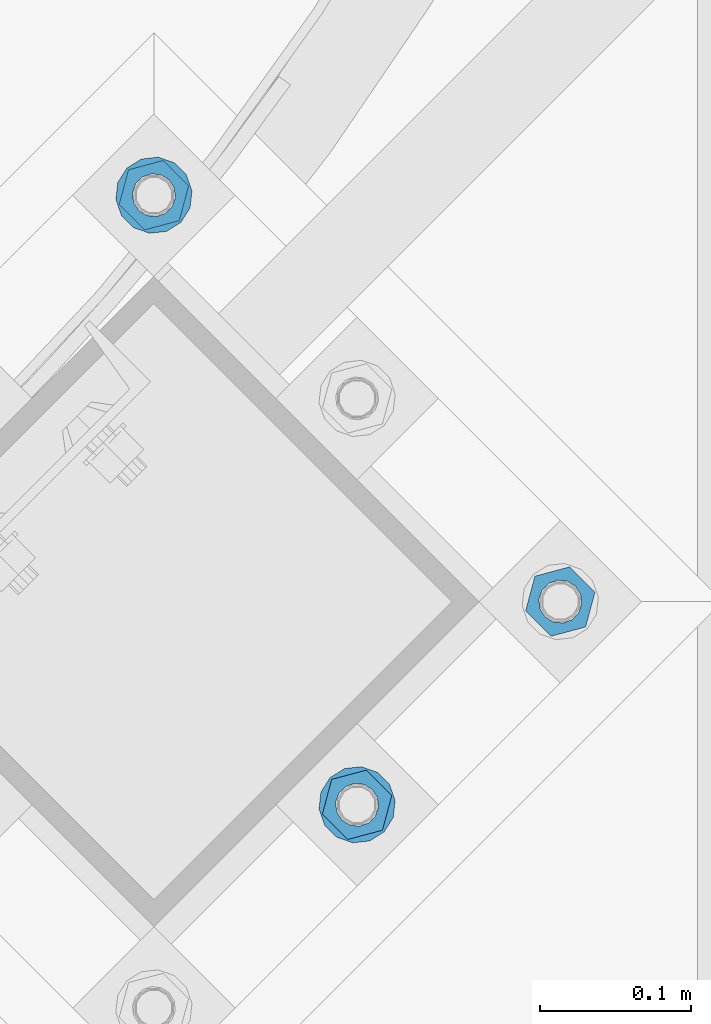
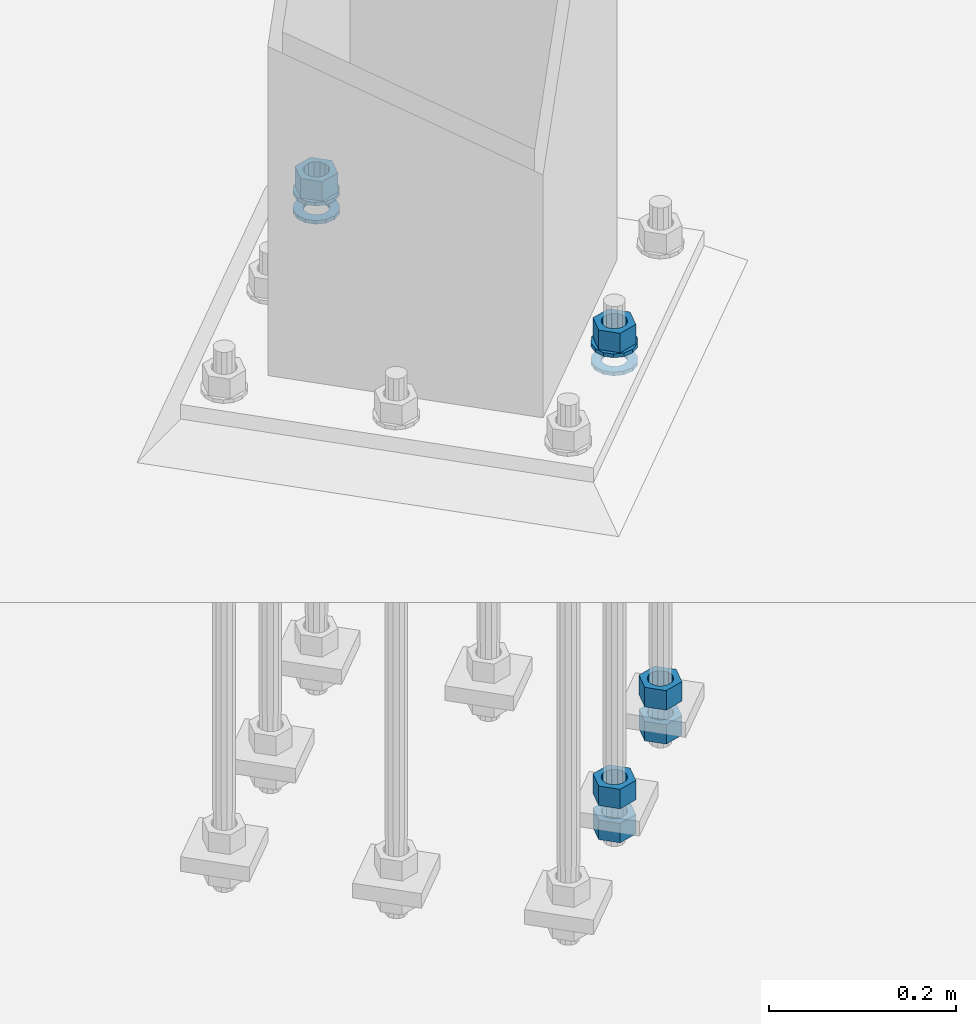
# One storey, part 867 of 1876: 10 columns, 1 element without a shape of its own.
"""IFC2X3 building model written with IfcOpenShell, lengths in millimetres."""

from ifc_helpers import new_model, si_unit, frame, origin_with_axes, place, context, subcontext, project, spatial, faceted_brep, material, type_object, element, aggregate, save


model = new_model("IFC2X3")

# Units and contexts
model_context = context("Model", 3, precision=1e-05, world=origin_with_axes())
body_context = subcontext(model_context, "Body", "Model", "MODEL_VIEW")
ifc_project = project(units=[si_unit("LENGTHUNIT", "METRE", prefix="MILLI"), si_unit("AREAUNIT", "SQUARE_METRE"), si_unit("VOLUMEUNIT", "CUBIC_METRE"), si_unit("MASSUNIT", "GRAM", prefix="KILO"), si_unit("TIMEUNIT", "SECOND"), si_unit("PLANEANGLEUNIT", "RADIAN"), si_unit("SOLIDANGLEUNIT", "STERADIAN"), si_unit("THERMODYNAMICTEMPERATUREUNIT", "DEGREE_CELSIUS"), si_unit("LUMINOUSINTENSITYUNIT", "LUMEN")], contexts=[model_context])

# Site, building, storey
site_placement = place(None, origin_with_axes())
site = spatial("IfcSite", under=ifc_project, at=site_placement, CompositionType="ELEMENT")
building_placement = place(site_placement, origin_with_axes())
building = spatial("IfcBuilding", under=site, at=building_placement, Name="Undefined", CompositionType="ELEMENT")
storey_placement = place(building_placement, origin_with_axes())
storey = spatial("IfcBuildingStorey", under=building, at=storey_placement, Name="Undefined", CompositionType="ELEMENT", Elevation=0.0)

# Assembly, columns
assembly_placement = place(storey_placement, origin_with_axes())
assembly = element("IfcElementAssembly", 1, at=assembly_placement, inside=storey, Name="TEMPLATE", AssemblyPlace="NOTDEFINED", PredefinedType="RIGID_FRAME")
ifc_material_1 = material(Name="STEEL/A563")
column_type_1 = type_object("IfcColumnType", Name="1_HEAVY_HEX_NUT", PredefinedType="NOTDEFINED")
column_1_placement = place(assembly_placement, frame((6849.68257448893, -14987.5323904103, -508.0), z_axis=(0.707106781186548, 0.707106781186547, 0.0), x_axis=(0.0, 0.0, -1.0)))
column_1 = element("IfcColumn", 2, at=column_1_placement, type_object=column_type_1, material=ifc_material_1, Name="NUT", ObjectType="1_HEAVY_HEX_NUT", context=body_context, shape_type="Brep", body=[
    faceted_brep([(0.0, -23.8099994659442, 9.09494701772928e-13), (0.0, -11.9099998474121, -20.6200008392352), (25.4, -11.9099998474157, -20.6200008392361), (25.4, -23.8099994659478, 0.0), (0.0, 11.9099998474157, -20.620000839237), (25.4, 11.9099998474121, -20.620000839237), (0.0, 23.8099994659478, 9.09494701772928e-13), (25.4, 23.8099994659442, 0.0), (0.0, 11.9099998474157, 20.620000839237), (25.4, 11.9099998474121, 20.620000839237), (0.0, -11.9099998474121, 20.6200008392389), (25.4, -11.9099998474157, 20.6200008392379), (0.0, 1.81898940354586e-12, 14.2899999618567), (0.0, 6.20019861543915, 12.8748450879584), (25.4, 6.20019861543733, 12.8748450879593), (25.4, 0.0, 14.2899999618558), (0.0, 11.1723718546473, 8.90966924477925), (25.4, 11.1723718546436, 8.90966924477925), (0.0, 13.9317198278914, 3.17982413774916), (25.4, 13.9317198278877, 3.17982413775007), (0.0, 13.9317198278914, -3.17982413774644), (25.4, 13.9317198278895, -3.17982413774735), (0.0, 11.1723718546473, -8.90966924477834), (25.4, 11.1723718546455, -8.90966924477925), (0.0, 6.20019861544279, -12.8748450879575), (25.4, 6.20019861543915, -12.8748450879584), (0.0, 3.63797880709171e-12, -14.2899999618548), (25.4, -3.63797880709171e-12, -14.2899999618548), (0.0, -6.20019861543733, -12.8748450879566), (25.4, -6.20019861544097, -12.8748450879584), (0.0, -11.1723718546455, -8.90966924477743), (25.4, -11.1723718546473, -8.90966924477834), (0.0, -13.9317198278877, -3.17982413774735), (25.4, -13.9317198278914, -3.17982413774826), (0.0, -13.9317198278895, 3.17982413774735), (25.4, -13.9317198278914, 3.17982413774826), (0.0, -11.1723718546455, 8.90966924477925), (25.4, -11.1723718546473, 8.90966924478016), (0.0, -6.20019861543915, 12.8748450879593), (25.4, -6.20019861544279, 12.8748450879593)], [[[0, 1, 2, 3]], [[1, 4, 5, 2]], [[4, 6, 7, 5]], [[6, 8, 9, 7]], [[8, 10, 11, 9]], [[10, 0, 3, 11]], [[12, 13, 14, 15]], [[13, 16, 17, 14]], [[16, 18, 19, 17]], [[18, 20, 21, 19]], [[20, 22, 23, 21]], [[22, 24, 25, 23]], [[24, 26, 27, 25]], [[26, 28, 29, 27]], [[28, 30, 31, 29]], [[30, 32, 33, 31]], [[32, 34, 35, 33]], [[34, 36, 37, 35]], [[36, 38, 39, 37]], [[38, 12, 15, 39]], [[5, 7, 9, 11, 3, 2], [17, 19, 21, 23, 25, 27, 29, 31, 33, 35, 37, 39, 15, 14]], [[10, 8, 6, 4, 1, 0], [38, 36, 34, 32, 30, 28, 26, 24, 22, 20, 18, 16, 13, 12]]]),
])
column_2_placement = place(assembly_placement, frame((6849.68257448893, -14987.5323904103, -552.45), z_axis=(0.707106781186548, 0.707106781186547, 0.0), x_axis=(0.0, 0.0, -1.0)))
column_2 = element("IfcColumn", 3, at=column_2_placement, type_object=column_type_1, material=ifc_material_1, Name="NUT", ObjectType="1_HEAVY_HEX_NUT", context=body_context, shape_type="Brep", body=[
    faceted_brep([(0.0, -23.8099994659442, 9.09494701772928e-13), (0.0, -11.9099998474121, -20.6200008392352), (25.4, -11.9099998474157, -20.6200008392361), (25.4, -23.8099994659478, 0.0), (0.0, 11.9099998474157, -20.620000839237), (25.4, 11.9099998474121, -20.620000839237), (0.0, 23.8099994659478, 9.09494701772928e-13), (25.4, 23.8099994659442, 0.0), (0.0, 11.9099998474157, 20.620000839237), (25.4, 11.9099998474121, 20.620000839237), (0.0, -11.9099998474121, 20.6200008392389), (25.4, -11.9099998474157, 20.6200008392379), (0.0, 1.81898940354586e-12, 14.2899999618567), (0.0, 6.20019861543915, 12.8748450879584), (25.4, 6.20019861543733, 12.8748450879593), (25.4, 0.0, 14.2899999618558), (0.0, 11.1723718546473, 8.90966924477925), (25.4, 11.1723718546436, 8.90966924477925), (0.0, 13.9317198278914, 3.17982413774916), (25.4, 13.9317198278877, 3.17982413775007), (0.0, 13.9317198278914, -3.17982413774644), (25.4, 13.9317198278895, -3.17982413774735), (0.0, 11.1723718546473, -8.90966924477834), (25.4, 11.1723718546455, -8.90966924477925), (0.0, 6.20019861544279, -12.8748450879575), (25.4, 6.20019861543915, -12.8748450879584), (0.0, 3.63797880709171e-12, -14.2899999618548), (25.4, -3.63797880709171e-12, -14.2899999618548), (0.0, -6.20019861543733, -12.8748450879566), (25.4, -6.20019861544097, -12.8748450879584), (0.0, -11.1723718546455, -8.90966924477743), (25.4, -11.1723718546473, -8.90966924477834), (0.0, -13.9317198278877, -3.17982413774735), (25.4, -13.9317198278914, -3.17982413774826), (0.0, -13.9317198278895, 3.17982413774735), (25.4, -13.9317198278914, 3.17982413774826), (0.0, -11.1723718546455, 8.90966924477925), (25.4, -11.1723718546473, 8.90966924478016), (0.0, -6.20019861543915, 12.8748450879593), (25.4, -6.20019861544279, 12.8748450879593)], [[[0, 1, 2, 3]], [[1, 4, 5, 2]], [[4, 6, 7, 5]], [[6, 8, 9, 7]], [[8, 10, 11, 9]], [[10, 0, 3, 11]], [[12, 13, 14, 15]], [[13, 16, 17, 14]], [[16, 18, 19, 17]], [[18, 20, 21, 19]], [[20, 22, 23, 21]], [[22, 24, 25, 23]], [[24, 26, 27, 25]], [[26, 28, 29, 27]], [[28, 30, 31, 29]], [[30, 32, 33, 31]], [[32, 34, 35, 33]], [[34, 36, 37, 35]], [[36, 38, 39, 37]], [[38, 12, 15, 39]], [[5, 7, 9, 11, 3, 2], [17, 19, 21, 23, 25, 27, 29, 31, 33, 35, 37, 39, 15, 14]], [[10, 8, 6, 4, 1, 0], [38, 36, 34, 32, 30, 28, 26, 24, 22, 20, 18, 16, 13, 12]]]),
])
column_3_placement = place(assembly_placement, frame((6580.27489085662, -14718.124706778, 87.3125), z_axis=(-0.707106781186547, -0.707106781186548, 0.0), x_axis=(0.0, 0.0, -1.0)))
column_3 = element("IfcColumn", 4, at=column_3_placement, type_object=column_type_1, material=ifc_material_1, Name="NUT", ObjectType="1_HEAVY_HEX_NUT", context=body_context, shape_type="Brep", body=[
    faceted_brep([(0.0, -23.8099994659442, 9.09494701772928e-13), (0.0, -11.9099998474121, -20.6200008392352), (25.4, -11.9099998474157, -20.6200008392361), (25.4, -23.8099994659478, 0.0), (0.0, 11.9099998474157, -20.620000839237), (25.4, 11.9099998474121, -20.620000839237), (0.0, 23.8099994659478, 9.09494701772928e-13), (25.4, 23.8099994659442, 0.0), (0.0, 11.9099998474157, 20.620000839237), (25.4, 11.9099998474121, 20.620000839237), (0.0, -11.9099998474121, 20.6200008392389), (25.4, -11.9099998474157, 20.6200008392379), (0.0, 1.81898940354586e-12, 14.2899999618567), (0.0, 6.20019861543915, 12.8748450879584), (25.4, 6.20019861543733, 12.8748450879593), (25.4, 0.0, 14.2899999618558), (0.0, 11.1723718546473, 8.90966924477925), (25.4, 11.1723718546436, 8.90966924477925), (0.0, 13.9317198278914, 3.17982413774916), (25.4, 13.9317198278877, 3.17982413775007), (0.0, 13.9317198278914, -3.17982413774644), (25.4, 13.9317198278895, -3.17982413774735), (0.0, 11.1723718546473, -8.90966924477834), (25.4, 11.1723718546455, -8.90966924477925), (0.0, 6.20019861544279, -12.8748450879575), (25.4, 6.20019861543915, -12.8748450879584), (0.0, 3.63797880709171e-12, -14.2899999618548), (25.4, -3.63797880709171e-12, -14.2899999618548), (0.0, -6.20019861543733, -12.8748450879566), (25.4, -6.20019861544097, -12.8748450879584), (0.0, -11.1723718546455, -8.90966924477743), (25.4, -11.1723718546473, -8.90966924477834), (0.0, -13.9317198278877, -3.17982413774735), (25.4, -13.9317198278914, -3.17982413774826), (0.0, -13.9317198278895, 3.17982413774735), (25.4, -13.9317198278914, 3.17982413774826), (0.0, -11.1723718546455, 8.90966924477925), (25.4, -11.1723718546473, 8.90966924478016), (0.0, -6.20019861543915, 12.8748450879593), (25.4, -6.20019861544279, 12.8748450879593)], [[[0, 1, 2, 3]], [[1, 4, 5, 2]], [[4, 6, 7, 5]], [[6, 8, 9, 7]], [[8, 10, 11, 9]], [[10, 0, 3, 11]], [[12, 13, 14, 15]], [[13, 16, 17, 14]], [[16, 18, 19, 17]], [[18, 20, 21, 19]], [[20, 22, 23, 21]], [[22, 24, 25, 23]], [[24, 26, 27, 25]], [[26, 28, 29, 27]], [[28, 30, 31, 29]], [[30, 32, 33, 31]], [[32, 34, 35, 33]], [[34, 36, 37, 35]], [[36, 38, 39, 37]], [[38, 12, 15, 39]], [[5, 7, 9, 11, 3, 2], [17, 19, 21, 23, 25, 27, 29, 31, 33, 35, 37, 39, 15, 14]], [[10, 8, 6, 4, 1, 0], [38, 36, 34, 32, 30, 28, 26, 24, 22, 20, 18, 16, 13, 12]]]),
])
column_4_placement = place(assembly_placement, frame((6714.97873267278, -15122.2362322265, 87.3125), z_axis=(0.707106781186548, 0.707106781186547, 0.0), x_axis=(0.0, 0.0, -1.0)))
column_4 = element("IfcColumn", 5, at=column_4_placement, type_object=column_type_1, material=ifc_material_1, Name="NUT", ObjectType="1_HEAVY_HEX_NUT", context=body_context, shape_type="Brep", body=[
    faceted_brep([(0.0, -23.8099994659442, 9.09494701772928e-13), (0.0, -11.9099998474121, -20.6200008392352), (25.4, -11.9099998474157, -20.6200008392361), (25.4, -23.8099994659478, 0.0), (0.0, 11.9099998474157, -20.620000839237), (25.4, 11.9099998474121, -20.620000839237), (0.0, 23.8099994659478, 9.09494701772928e-13), (25.4, 23.8099994659442, 0.0), (0.0, 11.9099998474157, 20.620000839237), (25.4, 11.9099998474121, 20.620000839237), (0.0, -11.9099998474121, 20.6200008392389), (25.4, -11.9099998474157, 20.6200008392379), (0.0, 1.81898940354586e-12, 14.2899999618567), (0.0, 6.20019861543915, 12.8748450879584), (25.4, 6.20019861543733, 12.8748450879593), (25.4, 0.0, 14.2899999618558), (0.0, 11.1723718546473, 8.90966924477925), (25.4, 11.1723718546436, 8.90966924477925), (0.0, 13.9317198278914, 3.17982413774916), (25.4, 13.9317198278877, 3.17982413775007), (0.0, 13.9317198278914, -3.17982413774644), (25.4, 13.9317198278895, -3.17982413774735), (0.0, 11.1723718546473, -8.90966924477834), (25.4, 11.1723718546455, -8.90966924477925), (0.0, 6.20019861544279, -12.8748450879575), (25.4, 6.20019861543915, -12.8748450879584), (0.0, 3.63797880709171e-12, -14.2899999618548), (25.4, -3.63797880709171e-12, -14.2899999618548), (0.0, -6.20019861543733, -12.8748450879566), (25.4, -6.20019861544097, -12.8748450879584), (0.0, -11.1723718546455, -8.90966924477743), (25.4, -11.1723718546473, -8.90966924477834), (0.0, -13.9317198278877, -3.17982413774735), (25.4, -13.9317198278914, -3.17982413774826), (0.0, -13.9317198278895, 3.17982413774735), (25.4, -13.9317198278914, 3.17982413774826), (0.0, -11.1723718546455, 8.90966924477925), (25.4, -11.1723718546473, 8.90966924478016), (0.0, -6.20019861543915, 12.8748450879593), (25.4, -6.20019861544279, 12.8748450879593)], [[[0, 1, 2, 3]], [[1, 4, 5, 2]], [[4, 6, 7, 5]], [[6, 8, 9, 7]], [[8, 10, 11, 9]], [[10, 0, 3, 11]], [[12, 13, 14, 15]], [[13, 16, 17, 14]], [[16, 18, 19, 17]], [[18, 20, 21, 19]], [[20, 22, 23, 21]], [[22, 24, 25, 23]], [[24, 26, 27, 25]], [[26, 28, 29, 27]], [[28, 30, 31, 29]], [[30, 32, 33, 31]], [[32, 34, 35, 33]], [[34, 36, 37, 35]], [[36, 38, 39, 37]], [[38, 12, 15, 39]], [[5, 7, 9, 11, 3, 2], [17, 19, 21, 23, 25, 27, 29, 31, 33, 35, 37, 39, 15, 14]], [[10, 8, 6, 4, 1, 0], [38, 36, 34, 32, 30, 28, 26, 24, 22, 20, 18, 16, 13, 12]]]),
])
column_5_placement = place(assembly_placement, frame((6714.97873267278, -15122.2362322265, -508.0), z_axis=(0.707106781186548, 0.707106781186547, 0.0), x_axis=(0.0, 0.0, -1.0)))
column_5 = element("IfcColumn", 6, at=column_5_placement, type_object=column_type_1, material=ifc_material_1, Name="NUT", ObjectType="1_HEAVY_HEX_NUT", context=body_context, shape_type="Brep", body=[
    faceted_brep([(0.0, -23.8099994659442, 9.09494701772928e-13), (0.0, -11.9099998474121, -20.6200008392352), (25.4, -11.9099998474157, -20.6200008392361), (25.4, -23.8099994659478, 0.0), (0.0, 11.9099998474157, -20.620000839237), (25.4, 11.9099998474121, -20.620000839237), (0.0, 23.8099994659478, 9.09494701772928e-13), (25.4, 23.8099994659442, 0.0), (0.0, 11.9099998474157, 20.620000839237), (25.4, 11.9099998474121, 20.620000839237), (0.0, -11.9099998474121, 20.6200008392389), (25.4, -11.9099998474157, 20.6200008392379), (0.0, 1.81898940354586e-12, 14.2899999618567), (0.0, 6.20019861543915, 12.8748450879584), (25.4, 6.20019861543733, 12.8748450879593), (25.4, 0.0, 14.2899999618558), (0.0, 11.1723718546473, 8.90966924477925), (25.4, 11.1723718546436, 8.90966924477925), (0.0, 13.9317198278914, 3.17982413774916), (25.4, 13.9317198278877, 3.17982413775007), (0.0, 13.9317198278914, -3.17982413774644), (25.4, 13.9317198278895, -3.17982413774735), (0.0, 11.1723718546473, -8.90966924477834), (25.4, 11.1723718546455, -8.90966924477925), (0.0, 6.20019861544279, -12.8748450879575), (25.4, 6.20019861543915, -12.8748450879584), (0.0, 3.63797880709171e-12, -14.2899999618548), (25.4, -3.63797880709171e-12, -14.2899999618548), (0.0, -6.20019861543733, -12.8748450879566), (25.4, -6.20019861544097, -12.8748450879584), (0.0, -11.1723718546455, -8.90966924477743), (25.4, -11.1723718546473, -8.90966924477834), (0.0, -13.9317198278877, -3.17982413774735), (25.4, -13.9317198278914, -3.17982413774826), (0.0, -13.9317198278895, 3.17982413774735), (25.4, -13.9317198278914, 3.17982413774826), (0.0, -11.1723718546455, 8.90966924477925), (25.4, -11.1723718546473, 8.90966924478016), (0.0, -6.20019861543915, 12.8748450879593), (25.4, -6.20019861544279, 12.8748450879593)], [[[0, 1, 2, 3]], [[1, 4, 5, 2]], [[4, 6, 7, 5]], [[6, 8, 9, 7]], [[8, 10, 11, 9]], [[10, 0, 3, 11]], [[12, 13, 14, 15]], [[13, 16, 17, 14]], [[16, 18, 19, 17]], [[18, 20, 21, 19]], [[20, 22, 23, 21]], [[22, 24, 25, 23]], [[24, 26, 27, 25]], [[26, 28, 29, 27]], [[28, 30, 31, 29]], [[30, 32, 33, 31]], [[32, 34, 35, 33]], [[34, 36, 37, 35]], [[36, 38, 39, 37]], [[38, 12, 15, 39]], [[5, 7, 9, 11, 3, 2], [17, 19, 21, 23, 25, 27, 29, 31, 33, 35, 37, 39, 15, 14]], [[10, 8, 6, 4, 1, 0], [38, 36, 34, 32, 30, 28, 26, 24, 22, 20, 18, 16, 13, 12]]]),
])
column_6_placement = place(assembly_placement, frame((6714.97873267278, -15122.2362322265, -552.45), z_axis=(0.707106781186548, 0.707106781186547, 0.0), x_axis=(0.0, 0.0, -1.0)))
column_6 = element("IfcColumn", 7, at=column_6_placement, type_object=column_type_1, material=ifc_material_1, Name="NUT", ObjectType="1_HEAVY_HEX_NUT", context=body_context, shape_type="Brep", body=[
    faceted_brep([(0.0, -23.8099994659442, 9.09494701772928e-13), (0.0, -11.9099998474121, -20.6200008392352), (25.4, -11.9099998474157, -20.6200008392361), (25.4, -23.8099994659478, 0.0), (0.0, 11.9099998474157, -20.620000839237), (25.4, 11.9099998474121, -20.620000839237), (0.0, 23.8099994659478, 9.09494701772928e-13), (25.4, 23.8099994659442, 0.0), (0.0, 11.9099998474157, 20.620000839237), (25.4, 11.9099998474121, 20.620000839237), (0.0, -11.9099998474121, 20.6200008392389), (25.4, -11.9099998474157, 20.6200008392379), (0.0, 1.81898940354586e-12, 14.2899999618567), (0.0, 6.20019861543915, 12.8748450879584), (25.4, 6.20019861543733, 12.8748450879593), (25.4, 0.0, 14.2899999618558), (0.0, 11.1723718546473, 8.90966924477925), (25.4, 11.1723718546436, 8.90966924477925), (0.0, 13.9317198278914, 3.17982413774916), (25.4, 13.9317198278877, 3.17982413775007), (0.0, 13.9317198278914, -3.17982413774644), (25.4, 13.9317198278895, -3.17982413774735), (0.0, 11.1723718546473, -8.90966924477834), (25.4, 11.1723718546455, -8.90966924477925), (0.0, 6.20019861544279, -12.8748450879575), (25.4, 6.20019861543915, -12.8748450879584), (0.0, 3.63797880709171e-12, -14.2899999618548), (25.4, -3.63797880709171e-12, -14.2899999618548), (0.0, -6.20019861543733, -12.8748450879566), (25.4, -6.20019861544097, -12.8748450879584), (0.0, -11.1723718546455, -8.90966924477743), (25.4, -11.1723718546473, -8.90966924477834), (0.0, -13.9317198278877, -3.17982413774735), (25.4, -13.9317198278914, -3.17982413774826), (0.0, -13.9317198278895, 3.17982413774735), (25.4, -13.9317198278914, 3.17982413774826), (0.0, -11.1723718546455, 8.90966924477925), (25.4, -11.1723718546473, 8.90966924478016), (0.0, -6.20019861543915, 12.8748450879593), (25.4, -6.20019861544279, 12.8748450879593)], [[[0, 1, 2, 3]], [[1, 4, 5, 2]], [[4, 6, 7, 5]], [[6, 8, 9, 7]], [[8, 10, 11, 9]], [[10, 0, 3, 11]], [[12, 13, 14, 15]], [[13, 16, 17, 14]], [[16, 18, 19, 17]], [[18, 20, 21, 19]], [[20, 22, 23, 21]], [[22, 24, 25, 23]], [[24, 26, 27, 25]], [[26, 28, 29, 27]], [[28, 30, 31, 29]], [[30, 32, 33, 31]], [[32, 34, 35, 33]], [[34, 36, 37, 35]], [[36, 38, 39, 37]], [[38, 12, 15, 39]], [[5, 7, 9, 11, 3, 2], [17, 19, 21, 23, 25, 27, 29, 31, 33, 35, 37, 39, 15, 14]], [[10, 8, 6, 4, 1, 0], [38, 36, 34, 32, 30, 28, 26, 24, 22, 20, 18, 16, 13, 12]]]),
])
ifc_material_2 = material(Name="STEEL/F436")
column_type_2 = type_object("IfcColumnType", Name="1_WASHER", PredefinedType="NOTDEFINED")
column_7_placement = place(assembly_placement, frame((6580.27489085662, -14718.124706778, 38.1), z_axis=(-0.707106781186547, -0.707106781186548, 0.0), x_axis=(0.0, 0.0, -1.0)))
column_7 = element("IfcColumn", 8, at=column_7_placement, type_object=column_type_2, material=ifc_material_2, Name="WASHER", ObjectType="1_WASHER", context=body_context, shape_type="Brep", body=[
    faceted_brep([(0.0, -25.3999996185375, 0.0), (0.0, -22.8846089010331, -11.0206468080742), (4.7625, -22.8846089010331, -11.0206468080742), (4.7625, -25.3999996185375, 0.0), (0.0, -15.8366407293743, -19.8585193564477), (4.7625, -15.8366407293743, -19.8585193564477), (0.0, -5.65203163760816, -24.7631685975166), (4.7625, -5.65203163760816, -24.7631685975166), (0.0, 5.65203163760452, -24.7631685975166), (4.7625, 5.65203163760452, -24.7631685975166), (0.0, 15.8366407293706, -19.858519356445), (4.7625, 15.8366407293706, -19.858519356445), (0.0, 22.8846089010331, -11.0206468080733), (4.7625, 22.8846089010331, -11.0206468080733), (0.0, 25.3999996185339, 9.09494701772928e-13), (4.7625, 25.3999996185339, 9.09494701772928e-13), (0.0, 22.8846089010331, 11.0206468080751), (4.7625, 22.8846089010331, 11.0206468080751), (0.0, 15.8366407293706, 19.8585193564486), (4.7625, 15.8366407293706, 19.8585193564486), (0.0, 5.65203163760452, 24.7631685975175), (4.7625, 5.65203163760452, 24.7631685975175), (0.0, -5.65203163760816, 24.7631685975175), (4.7625, -5.65203163760816, 24.7631685975175), (0.0, -15.8366407293724, 19.8585193564459), (4.7625, -15.8366407293724, 19.8585193564459), (0.0, -22.8846089010367, 11.0206468080751), (4.7625, -22.8846089010367, 11.0206468080751), (0.0, 1.81898940354586e-12, 14.2899999618567), (0.0, 6.20019861543915, 12.8748450879584), (4.7625, 6.20019861543733, 12.8748450879593), (4.7625, 0.0, 14.2899999618558), (0.0, 11.1723718546473, 8.90966924477925), (4.7625, 11.1723718546436, 8.90966924477925), (0.0, 13.9317198278914, 3.17982413774916), (4.7625, 13.9317198278877, 3.17982413775007), (0.0, 13.9317198278914, -3.17982413774644), (4.7625, 13.9317198278895, -3.17982413774735), (0.0, 11.1723718546473, -8.90966924477834), (4.7625, 11.1723718546455, -8.90966924477925), (0.0, 6.20019861544279, -12.8748450879575), (4.7625, 6.20019861543915, -12.8748450879584), (0.0, 3.63797880709171e-12, -14.2899999618548), (4.7625, -3.63797880709171e-12, -14.2899999618548), (0.0, -6.20019861543733, -12.8748450879566), (4.7625, -6.20019861544097, -12.8748450879584), (0.0, -11.1723718546455, -8.90966924477743), (4.7625, -11.1723718546473, -8.90966924477834), (0.0, -13.9317198278877, -3.17982413774735), (4.7625, -13.9317198278914, -3.17982413774826), (0.0, -13.9317198278895, 3.17982413774735), (4.7625, -13.9317198278914, 3.17982413774826), (0.0, -11.1723718546455, 8.90966924477925), (4.7625, -11.1723718546473, 8.90966924478016), (0.0, -6.20019861543915, 12.8748450879593), (4.7625, -6.20019861544279, 12.8748450879593)], [[[0, 1, 2, 3]], [[1, 4, 5, 2]], [[4, 6, 7, 5]], [[6, 8, 9, 7]], [[8, 10, 11, 9]], [[10, 12, 13, 11]], [[12, 14, 15, 13]], [[14, 16, 17, 15]], [[16, 18, 19, 17]], [[18, 20, 21, 19]], [[20, 22, 23, 21]], [[22, 24, 25, 23]], [[24, 26, 27, 25]], [[26, 0, 3, 27]], [[28, 29, 30, 31]], [[29, 32, 33, 30]], [[32, 34, 35, 33]], [[34, 36, 37, 35]], [[36, 38, 39, 37]], [[38, 40, 41, 39]], [[40, 42, 43, 41]], [[42, 44, 45, 43]], [[44, 46, 47, 45]], [[46, 48, 49, 47]], [[48, 50, 51, 49]], [[50, 52, 53, 51]], [[52, 54, 55, 53]], [[54, 28, 31, 55]], [[5, 7, 9, 11, 13, 15, 17, 19, 21, 23, 25, 27, 3, 2], [33, 35, 37, 39, 41, 43, 45, 47, 49, 51, 53, 55, 31, 30]], [[26, 24, 22, 20, 18, 16, 14, 12, 10, 8, 6, 4, 1, 0], [54, 52, 50, 48, 46, 44, 42, 40, 38, 36, 34, 32, 29, 28]]]),
])
column_8_placement = place(assembly_placement, frame((6580.27489085662, -14718.124706778, 61.9125), z_axis=(-0.707106781186547, -0.707106781186548, 0.0), x_axis=(0.0, 0.0, -1.0)))
column_8 = element("IfcColumn", 9, at=column_8_placement, type_object=column_type_2, material=ifc_material_2, Name="WASHER", ObjectType="1_WASHER", context=body_context, shape_type="Brep", body=[
    faceted_brep([(0.0, -25.3999996185375, 0.0), (0.0, -22.8846089010331, -11.0206468080742), (4.7625, -22.8846089010331, -11.0206468080742), (4.7625, -25.3999996185375, 0.0), (0.0, -15.8366407293743, -19.8585193564477), (4.7625, -15.8366407293743, -19.8585193564477), (0.0, -5.65203163760816, -24.7631685975166), (4.7625, -5.65203163760816, -24.7631685975166), (0.0, 5.65203163760452, -24.7631685975166), (4.7625, 5.65203163760452, -24.7631685975166), (0.0, 15.8366407293706, -19.858519356445), (4.7625, 15.8366407293706, -19.858519356445), (0.0, 22.8846089010331, -11.0206468080733), (4.7625, 22.8846089010331, -11.0206468080733), (0.0, 25.3999996185339, 9.09494701772928e-13), (4.7625, 25.3999996185339, 9.09494701772928e-13), (0.0, 22.8846089010331, 11.0206468080751), (4.7625, 22.8846089010331, 11.0206468080751), (0.0, 15.8366407293706, 19.8585193564486), (4.7625, 15.8366407293706, 19.8585193564486), (0.0, 5.65203163760452, 24.7631685975175), (4.7625, 5.65203163760452, 24.7631685975175), (0.0, -5.65203163760816, 24.7631685975175), (4.7625, -5.65203163760816, 24.7631685975175), (0.0, -15.8366407293724, 19.8585193564459), (4.7625, -15.8366407293724, 19.8585193564459), (0.0, -22.8846089010367, 11.0206468080751), (4.7625, -22.8846089010367, 11.0206468080751), (0.0, 1.81898940354586e-12, 14.2899999618567), (0.0, 6.20019861543915, 12.8748450879584), (4.7625, 6.20019861543733, 12.8748450879593), (4.7625, 0.0, 14.2899999618558), (0.0, 11.1723718546473, 8.90966924477925), (4.7625, 11.1723718546436, 8.90966924477925), (0.0, 13.9317198278914, 3.17982413774916), (4.7625, 13.9317198278877, 3.17982413775007), (0.0, 13.9317198278914, -3.17982413774644), (4.7625, 13.9317198278895, -3.17982413774735), (0.0, 11.1723718546473, -8.90966924477834), (4.7625, 11.1723718546455, -8.90966924477925), (0.0, 6.20019861544279, -12.8748450879575), (4.7625, 6.20019861543915, -12.8748450879584), (0.0, 3.63797880709171e-12, -14.2899999618548), (4.7625, -3.63797880709171e-12, -14.2899999618548), (0.0, -6.20019861543733, -12.8748450879566), (4.7625, -6.20019861544097, -12.8748450879584), (0.0, -11.1723718546455, -8.90966924477743), (4.7625, -11.1723718546473, -8.90966924477834), (0.0, -13.9317198278877, -3.17982413774735), (4.7625, -13.9317198278914, -3.17982413774826), (0.0, -13.9317198278895, 3.17982413774735), (4.7625, -13.9317198278914, 3.17982413774826), (0.0, -11.1723718546455, 8.90966924477925), (4.7625, -11.1723718546473, 8.90966924478016), (0.0, -6.20019861543915, 12.8748450879593), (4.7625, -6.20019861544279, 12.8748450879593)], [[[0, 1, 2, 3]], [[1, 4, 5, 2]], [[4, 6, 7, 5]], [[6, 8, 9, 7]], [[8, 10, 11, 9]], [[10, 12, 13, 11]], [[12, 14, 15, 13]], [[14, 16, 17, 15]], [[16, 18, 19, 17]], [[18, 20, 21, 19]], [[20, 22, 23, 21]], [[22, 24, 25, 23]], [[24, 26, 27, 25]], [[26, 0, 3, 27]], [[28, 29, 30, 31]], [[29, 32, 33, 30]], [[32, 34, 35, 33]], [[34, 36, 37, 35]], [[36, 38, 39, 37]], [[38, 40, 41, 39]], [[40, 42, 43, 41]], [[42, 44, 45, 43]], [[44, 46, 47, 45]], [[46, 48, 49, 47]], [[48, 50, 51, 49]], [[50, 52, 53, 51]], [[52, 54, 55, 53]], [[54, 28, 31, 55]], [[5, 7, 9, 11, 13, 15, 17, 19, 21, 23, 25, 27, 3, 2], [33, 35, 37, 39, 41, 43, 45, 47, 49, 51, 53, 55, 31, 30]], [[26, 24, 22, 20, 18, 16, 14, 12, 10, 8, 6, 4, 1, 0], [54, 52, 50, 48, 46, 44, 42, 40, 38, 36, 34, 32, 29, 28]]]),
])
column_9_placement = place(assembly_placement, frame((6714.97873267278, -15122.2362322265, 38.1), z_axis=(0.707106781186548, 0.707106781186547, 0.0), x_axis=(0.0, 0.0, -1.0)))
column_9 = element("IfcColumn", 10, at=column_9_placement, type_object=column_type_2, material=ifc_material_2, Name="WASHER", ObjectType="1_WASHER", context=body_context, shape_type="Brep", body=[
    faceted_brep([(0.0, -25.3999996185375, 0.0), (0.0, -22.8846089010331, -11.0206468080742), (4.7625, -22.8846089010331, -11.0206468080742), (4.7625, -25.3999996185375, 0.0), (0.0, -15.8366407293743, -19.8585193564477), (4.7625, -15.8366407293743, -19.8585193564477), (0.0, -5.65203163760816, -24.7631685975166), (4.7625, -5.65203163760816, -24.7631685975166), (0.0, 5.65203163760452, -24.7631685975166), (4.7625, 5.65203163760452, -24.7631685975166), (0.0, 15.8366407293706, -19.858519356445), (4.7625, 15.8366407293706, -19.858519356445), (0.0, 22.8846089010331, -11.0206468080733), (4.7625, 22.8846089010331, -11.0206468080733), (0.0, 25.3999996185339, 9.09494701772928e-13), (4.7625, 25.3999996185339, 9.09494701772928e-13), (0.0, 22.8846089010331, 11.0206468080751), (4.7625, 22.8846089010331, 11.0206468080751), (0.0, 15.8366407293706, 19.8585193564486), (4.7625, 15.8366407293706, 19.8585193564486), (0.0, 5.65203163760452, 24.7631685975175), (4.7625, 5.65203163760452, 24.7631685975175), (0.0, -5.65203163760816, 24.7631685975175), (4.7625, -5.65203163760816, 24.7631685975175), (0.0, -15.8366407293724, 19.8585193564459), (4.7625, -15.8366407293724, 19.8585193564459), (0.0, -22.8846089010367, 11.0206468080751), (4.7625, -22.8846089010367, 11.0206468080751), (0.0, 1.81898940354586e-12, 14.2899999618567), (0.0, 6.20019861543915, 12.8748450879584), (4.7625, 6.20019861543733, 12.8748450879593), (4.7625, 0.0, 14.2899999618558), (0.0, 11.1723718546473, 8.90966924477925), (4.7625, 11.1723718546436, 8.90966924477925), (0.0, 13.9317198278914, 3.17982413774916), (4.7625, 13.9317198278877, 3.17982413775007), (0.0, 13.9317198278914, -3.17982413774644), (4.7625, 13.9317198278895, -3.17982413774735), (0.0, 11.1723718546473, -8.90966924477834), (4.7625, 11.1723718546455, -8.90966924477925), (0.0, 6.20019861544279, -12.8748450879575), (4.7625, 6.20019861543915, -12.8748450879584), (0.0, 3.63797880709171e-12, -14.2899999618548), (4.7625, -3.63797880709171e-12, -14.2899999618548), (0.0, -6.20019861543733, -12.8748450879566), (4.7625, -6.20019861544097, -12.8748450879584), (0.0, -11.1723718546455, -8.90966924477743), (4.7625, -11.1723718546473, -8.90966924477834), (0.0, -13.9317198278877, -3.17982413774735), (4.7625, -13.9317198278914, -3.17982413774826), (0.0, -13.9317198278895, 3.17982413774735), (4.7625, -13.9317198278914, 3.17982413774826), (0.0, -11.1723718546455, 8.90966924477925), (4.7625, -11.1723718546473, 8.90966924478016), (0.0, -6.20019861543915, 12.8748450879593), (4.7625, -6.20019861544279, 12.8748450879593)], [[[0, 1, 2, 3]], [[1, 4, 5, 2]], [[4, 6, 7, 5]], [[6, 8, 9, 7]], [[8, 10, 11, 9]], [[10, 12, 13, 11]], [[12, 14, 15, 13]], [[14, 16, 17, 15]], [[16, 18, 19, 17]], [[18, 20, 21, 19]], [[20, 22, 23, 21]], [[22, 24, 25, 23]], [[24, 26, 27, 25]], [[26, 0, 3, 27]], [[28, 29, 30, 31]], [[29, 32, 33, 30]], [[32, 34, 35, 33]], [[34, 36, 37, 35]], [[36, 38, 39, 37]], [[38, 40, 41, 39]], [[40, 42, 43, 41]], [[42, 44, 45, 43]], [[44, 46, 47, 45]], [[46, 48, 49, 47]], [[48, 50, 51, 49]], [[50, 52, 53, 51]], [[52, 54, 55, 53]], [[54, 28, 31, 55]], [[5, 7, 9, 11, 13, 15, 17, 19, 21, 23, 25, 27, 3, 2], [33, 35, 37, 39, 41, 43, 45, 47, 49, 51, 53, 55, 31, 30]], [[26, 24, 22, 20, 18, 16, 14, 12, 10, 8, 6, 4, 1, 0], [54, 52, 50, 48, 46, 44, 42, 40, 38, 36, 34, 32, 29, 28]]]),
])
column_10_placement = place(assembly_placement, frame((6714.97873267278, -15122.2362322265, 61.9125), z_axis=(0.707106781186548, 0.707106781186547, 0.0), x_axis=(0.0, 0.0, -1.0)))
column_10 = element("IfcColumn", 11, at=column_10_placement, type_object=column_type_2, material=ifc_material_2, Name="WASHER", ObjectType="1_WASHER", context=body_context, shape_type="Brep", body=[
    faceted_brep([(0.0, -25.3999996185375, 0.0), (0.0, -22.8846089010331, -11.0206468080742), (4.7625, -22.8846089010331, -11.0206468080742), (4.7625, -25.3999996185375, 0.0), (0.0, -15.8366407293743, -19.8585193564477), (4.7625, -15.8366407293743, -19.8585193564477), (0.0, -5.65203163760816, -24.7631685975166), (4.7625, -5.65203163760816, -24.7631685975166), (0.0, 5.65203163760452, -24.7631685975166), (4.7625, 5.65203163760452, -24.7631685975166), (0.0, 15.8366407293706, -19.858519356445), (4.7625, 15.8366407293706, -19.858519356445), (0.0, 22.8846089010331, -11.0206468080733), (4.7625, 22.8846089010331, -11.0206468080733), (0.0, 25.3999996185339, 9.09494701772928e-13), (4.7625, 25.3999996185339, 9.09494701772928e-13), (0.0, 22.8846089010331, 11.0206468080751), (4.7625, 22.8846089010331, 11.0206468080751), (0.0, 15.8366407293706, 19.8585193564486), (4.7625, 15.8366407293706, 19.8585193564486), (0.0, 5.65203163760452, 24.7631685975175), (4.7625, 5.65203163760452, 24.7631685975175), (0.0, -5.65203163760816, 24.7631685975175), (4.7625, -5.65203163760816, 24.7631685975175), (0.0, -15.8366407293724, 19.8585193564459), (4.7625, -15.8366407293724, 19.8585193564459), (0.0, -22.8846089010367, 11.0206468080751), (4.7625, -22.8846089010367, 11.0206468080751), (0.0, 1.81898940354586e-12, 14.2899999618567), (0.0, 6.20019861543915, 12.8748450879584), (4.7625, 6.20019861543733, 12.8748450879593), (4.7625, 0.0, 14.2899999618558), (0.0, 11.1723718546473, 8.90966924477925), (4.7625, 11.1723718546436, 8.90966924477925), (0.0, 13.9317198278914, 3.17982413774916), (4.7625, 13.9317198278877, 3.17982413775007), (0.0, 13.9317198278914, -3.17982413774644), (4.7625, 13.9317198278895, -3.17982413774735), (0.0, 11.1723718546473, -8.90966924477834), (4.7625, 11.1723718546455, -8.90966924477925), (0.0, 6.20019861544279, -12.8748450879575), (4.7625, 6.20019861543915, -12.8748450879584), (0.0, 3.63797880709171e-12, -14.2899999618548), (4.7625, -3.63797880709171e-12, -14.2899999618548), (0.0, -6.20019861543733, -12.8748450879566), (4.7625, -6.20019861544097, -12.8748450879584), (0.0, -11.1723718546455, -8.90966924477743), (4.7625, -11.1723718546473, -8.90966924477834), (0.0, -13.9317198278877, -3.17982413774735), (4.7625, -13.9317198278914, -3.17982413774826), (0.0, -13.9317198278895, 3.17982413774735), (4.7625, -13.9317198278914, 3.17982413774826), (0.0, -11.1723718546455, 8.90966924477925), (4.7625, -11.1723718546473, 8.90966924478016), (0.0, -6.20019861543915, 12.8748450879593), (4.7625, -6.20019861544279, 12.8748450879593)], [[[0, 1, 2, 3]], [[1, 4, 5, 2]], [[4, 6, 7, 5]], [[6, 8, 9, 7]], [[8, 10, 11, 9]], [[10, 12, 13, 11]], [[12, 14, 15, 13]], [[14, 16, 17, 15]], [[16, 18, 19, 17]], [[18, 20, 21, 19]], [[20, 22, 23, 21]], [[22, 24, 25, 23]], [[24, 26, 27, 25]], [[26, 0, 3, 27]], [[28, 29, 30, 31]], [[29, 32, 33, 30]], [[32, 34, 35, 33]], [[34, 36, 37, 35]], [[36, 38, 39, 37]], [[38, 40, 41, 39]], [[40, 42, 43, 41]], [[42, 44, 45, 43]], [[44, 46, 47, 45]], [[46, 48, 49, 47]], [[48, 50, 51, 49]], [[50, 52, 53, 51]], [[52, 54, 55, 53]], [[54, 28, 31, 55]], [[5, 7, 9, 11, 13, 15, 17, 19, 21, 23, 25, 27, 3, 2], [33, 35, 37, 39, 41, 43, 45, 47, 49, 51, 53, 55, 31, 30]], [[26, 24, 22, 20, 18, 16, 14, 12, 10, 8, 6, 4, 1, 0], [54, 52, 50, 48, 46, 44, 42, 40, 38, 36, 34, 32, 29, 28]]]),
])
aggregate(assembly, [column_1, column_2, column_3, column_7, column_8, column_4, column_9, column_10, column_5, column_6])

save(model, "model.ifc")
